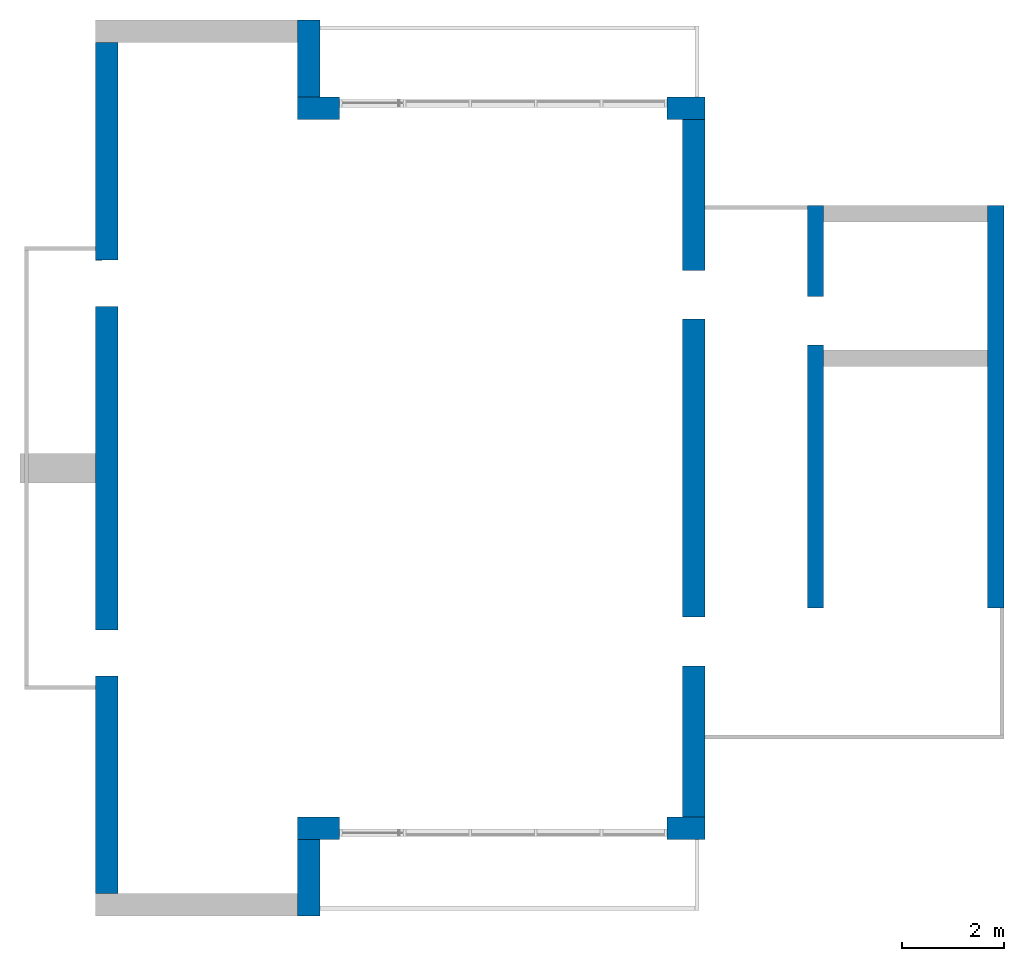
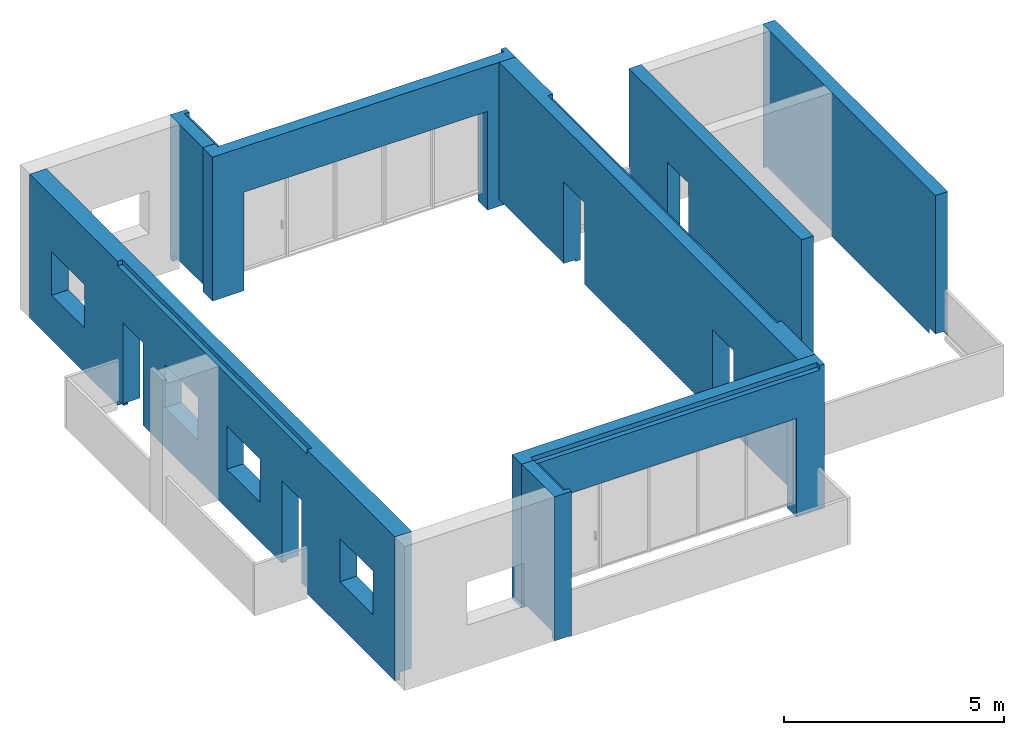
# One storey, part 3 of 4: 8 walls.
"""IFC2X3 building model written with IfcOpenShell, lengths in millimetres."""

from ifc_helpers import new_model, entity, si_unit, converted_unit, derived_unit, direction, frame, origin, place, context, subcontext, project, spatial, faceted_brep, material, material_list, layer, layer_set, type_object, element, save


model = new_model("IFC2X3")

# Units and contexts
model_context = context("Model", 3, precision=0.01, world=origin(), true_north=direction((6.12303176911189e-17, 1.0)))
body_context = subcontext(model_context, "Body", "Model", "MODEL_VIEW")
ifc_project = project(units=[si_unit("LENGTHUNIT", "METRE", prefix="MILLI"), si_unit("AREAUNIT", "SQUARE_METRE"), si_unit("VOLUMEUNIT", "CUBIC_METRE"), converted_unit("PLANEANGLEUNIT", "DEGREE", entity("IfcRatioMeasure", 0.0174532925199433), si_unit("PLANEANGLEUNIT", "RADIAN"), dimensions=[0, 0, 0, 0, 0, 0, 0]), si_unit("MASSUNIT", "GRAM", prefix="KILO"), derived_unit("MASSDENSITYUNIT", [(si_unit("MASSUNIT", "GRAM", prefix="KILO"), 1), (si_unit("LENGTHUNIT", "METRE"), -3)]), si_unit("TIMEUNIT", "SECOND"), si_unit("FREQUENCYUNIT", "HERTZ"), si_unit("THERMODYNAMICTEMPERATUREUNIT", "DEGREE_CELSIUS"), derived_unit("THERMALTRANSMITTANCEUNIT", [(si_unit("MASSUNIT", "GRAM", prefix="KILO"), 1), (si_unit("THERMODYNAMICTEMPERATUREUNIT", "KELVIN"), -1), (si_unit("TIMEUNIT", "SECOND"), -3)]), derived_unit("VOLUMETRICFLOWRATEUNIT", [(si_unit("LENGTHUNIT", "METRE"), 3), (si_unit("TIMEUNIT", "SECOND"), -1)]), si_unit("ELECTRICCURRENTUNIT", "AMPERE"), si_unit("ELECTRICVOLTAGEUNIT", "VOLT"), si_unit("POWERUNIT", "WATT"), si_unit("FORCEUNIT", "NEWTON", prefix="KILO"), si_unit("ILLUMINANCEUNIT", "LUX"), si_unit("LUMINOUSFLUXUNIT", "LUMEN"), si_unit("LUMINOUSINTENSITYUNIT", "CANDELA"), derived_unit("USERDEFINED", [(si_unit("MASSUNIT", "GRAM", prefix="KILO"), -1), (si_unit("LENGTHUNIT", "METRE"), -2), (si_unit("TIMEUNIT", "SECOND"), 3), (si_unit("LUMINOUSFLUXUNIT", "LUMEN"), 1)]), derived_unit("LINEARVELOCITYUNIT", [(si_unit("LENGTHUNIT", "METRE"), 1), (si_unit("TIMEUNIT", "SECOND"), -1)]), si_unit("PRESSUREUNIT", "PASCAL"), derived_unit("USERDEFINED", [(si_unit("LENGTHUNIT", "METRE"), -2), (si_unit("MASSUNIT", "GRAM", prefix="KILO"), 1), (si_unit("TIMEUNIT", "SECOND"), -2)])], contexts=[model_context])

# Site, building, storey
site_placement = place(None, origin())
site = spatial("IfcSite", under=ifc_project, at=site_placement, CompositionType="ELEMENT")
building_placement = place(site_placement, origin())
building = spatial("IfcBuilding", under=site, at=building_placement, CompositionType="ELEMENT")
storey_placement = place(building_placement, frame((0.0, 0.0, 4000.0)))
storey = spatial("IfcBuildingStorey", under=building, at=storey_placement, Name="01 Level", CompositionType="ELEMENT", Elevation=4000.0)

# Walls
ifc_material_1 = material(Name="03")
ifc_material_2 = material()
ifc_material_3 = material()
ifc_material_list_1 = material_list([ifc_material_1, ifc_material_2, ifc_material_3, ifc_material_1])
ifc_layer_1 = layer(ifc_material_1, 10.0)
ifc_layer_2 = layer(ifc_material_2, 120.0)
ifc_layer_3 = layer(ifc_material_3, 300.0)
ifc_layer_4 = layer(ifc_material_1, 10.0)
ifc_layer_set_1 = layer_set([ifc_layer_1, ifc_layer_2, ifc_layer_3, ifc_layer_4], Name="Basic Wall:00_fal+12 cm")
wall_type_1 = type_object("IfcWallType", Name="Basic Wall:00_fal+12 cm", PredefinedType="STANDARD", material=ifc_layer_set_1)
wall_1_placement = place(storey_placement, frame((28723.4900708518, -62021.23958514, -340.0), z_axis=(0.0, 0.0, 1.0), x_axis=(0.0, -1.0, 0.0)))
element("IfcWall", 1, at=wall_1_placement, inside=storey, type_object=wall_type_1, material=ifc_material_list_1, Name="Basic Wall:00_fal+12 cm", ObjectType="Basic Wall:00_fal+12 cm", context=body_context, shape_type="Brep", body=[
    faceted_brep([(13620.0, -220.0, 4000.0), (9620.0, -220.0, 4000.0), (9470.0, -220.0, 4000.0), (6970.0, -220.0, 4000.0), (6650.0, -220.0, 4000.0), (4150.0, -220.0, 4000.0), (4000.0, -220.0, 4000.0), (0.0, -220.0, 4000.0), (0.0, -220.0, 200.0), (2950.0, -220.0, 200.0), (2950.0, -220.0, 340.0), (2950.0, -220.0, 2465.0), (3900.0, -220.0, 2465.0), (3900.0, -220.0, 340.0), (3900.0, -220.0, 200.0), (4000.0, -220.0, 200.0), (4150.0, -220.0, 200.0), (6650.0, -220.0, 200.0), (6970.0, -220.0, 200.0), (9470.0, -220.0, 200.0), (9620.0, -220.0, 200.0), (9720.0, -220.0, 200.0), (9720.0, -220.0, 340.0), (9720.0, -220.0, 2465.0), (10670.0, -220.0, 2465.0), (10670.0, -220.0, 340.0), (10670.0, -220.0, 200.0), (13620.0, -220.0, 200.0), (10670.0, 220.0, 2465.0), (9720.0, 220.0, 2465.0), (9720.0, 220.0, 340.0), (9720.0, 220.0, 150.0), (3900.0, 220.0, 150.0), (3900.0, 220.0, 340.0), (3900.0, 220.0, 2465.0), (2950.0, 220.0, 2465.0), (2950.0, 220.0, 340.0), (2950.0, 220.0, 150.0), (1764.58460545632, 220.0, 150.0), (1694.58460545634, 220.0, 150.0), (1694.58460545634, 220.0, 0.0), (0.0, 220.0, 0.0), (0.0, 220.0, 4000.0), (1694.58460545634, 220.0, 4000.0), (1699.58460545631, 220.0, 4000.0), (1699.58460545631, 220.0, 3875.0), (12094.5846054563, 220.0, 3875.0), (12094.5846054563, 220.0, 4000.0), (13620.0, 220.0, 4000.0), (13620.0, 220.0, 0.0), (12040.0, 220.0, 0.0), (12039.5846054563, 220.0, 0.0), (12039.5846054563, 220.0, 150.0), (12024.5846054563, 220.0, 150.0), (10670.0, 220.0, 150.0), (10670.0, 220.0, 340.0), (1694.58460545634, 90.0, 0.0), (0.0, 90.0, 0.0), (13620.0, 90.0, 4000.0), (12094.5846054563, 90.0, 4000.0), (1699.58460545631, 90.0, 4000.0), (0.0, 90.0, 4000.0), (9720.0, -120.0, 200.0), (9720.0, 90.0, 200.0), (9720.0, 90.0, 150.0), (10670.0, 90.0, 150.0), (10670.0, 90.0, 200.0), (10670.0, -120.0, 200.0), (3900.0, 90.0, 150.0), (3900.0, 90.0, 200.0), (3900.0, -120.0, 200.0), (2950.0, -120.0, 200.0), (2950.0, 90.0, 200.0), (2950.0, 90.0, 150.0), (12039.5846054563, 90.0, 150.0), (12039.5846054563, 90.0, 0.0), (1694.58460545634, 90.0, 150.0), (13620.0, 90.0, 200.0), (0.0, 90.0, 200.0), (13620.0, 90.0, 0.0), (1699.58460545631, 90.0, 3875.0), (12094.5846054563, 90.0, 3875.0)], [[[0, 1, 2, 3, 4, 5, 6, 7, 8, 9, 10, 11, 12, 13, 14, 15, 16, 17, 18, 19, 20, 21, 22, 23, 24, 25, 26, 27]], [[28, 29, 30, 31, 32, 33, 34, 35, 36, 37, 38, 39, 40, 41, 42, 43, 44, 45, 46, 47, 48, 49, 50, 51, 52, 53, 54, 55]], [[41, 40, 56, 57]], [[7, 6, 5, 4, 3, 2, 1, 0, 58, 48, 47, 59, 60, 44, 43, 42, 61]], [[29, 23, 22, 21, 62, 63, 64, 31, 30]], [[24, 23, 29, 28]], [[24, 28, 55, 54, 65, 66, 67, 26, 25]], [[12, 34, 33, 32, 68, 69, 70, 14, 13]], [[12, 11, 35, 34]], [[35, 11, 10, 9, 71, 72, 73, 37, 36]], [[52, 74, 65, 54, 53]], [[74, 52, 51, 75]], [[39, 76, 56, 40]], [[77, 27, 26, 67, 66]], [[57, 56, 76, 73, 72, 78]], [[48, 58, 0, 27, 77, 79, 49]], [[7, 61, 42, 41, 57, 78, 8]], [[80, 81, 46, 45]], [[81, 80, 60, 59]], [[60, 80, 45, 44]], [[81, 59, 47, 46]], [[75, 79, 77, 66, 65, 74]], [[68, 64, 63, 69]], [[8, 78, 72, 71, 9]], [[21, 20, 19, 18, 17, 16, 15, 14, 70, 69, 63, 62]], [[64, 68, 32, 31]], [[76, 39, 38, 37, 73]], [[51, 50, 49, 79, 75]]]),
])
wall_2_placement = place(storey_placement, frame((21203.4900708518, -76081.2395851399, -340.0), z_axis=(0.0, 0.0, 1.0), x_axis=(0.0, -1.0, 0.0)))
element("IfcWall", 2, at=wall_2_placement, inside=storey, type_object=wall_type_1, Name="Basic Wall:00_fal+12 cm", ObjectType="Basic Wall:00_fal+12 cm", context=body_context, shape_type="Brep", body=[
    faceted_brep([(1500.0, -220.0, 4000.0), (1370.0, -220.0, 4000.0), (1060.0, -220.0, 4000.0), (0.0, -220.0, 4000.0), (0.0, -220.0, 200.0), (1370.0, -220.0, 200.0), (1370.0, -220.0, 0.0), (1500.0, -220.0, 0.0), (1500.0, 220.0, 4000.0), (1500.0, 220.0, 0.0), (1370.0, 220.0, 0.0), (1370.0, 220.0, 150.0), (1305.0, 220.0, 150.0), (0.0, 220.0, 150.0), (0.0, 220.0, 3875.0), (1370.0, 220.0, 3875.0), (1370.0, 220.0, 4000.0), (1370.0, 90.0, 0.0), (1370.0, 90.0, 4000.0), (0.0, 90.0, 4000.0), (1370.0, 90.0, 3875.0), (0.0, 90.0, 3875.0), (0.0, 90.0, 150.0), (0.0, 90.0, 200.0), (1370.0, 90.0, 200.0), (1370.0, 90.0, 150.0)], [[[0, 1, 2, 3, 4, 5, 6, 7]], [[8, 9, 10, 11, 12, 13, 14, 15, 16]], [[9, 7, 6, 17, 10]], [[3, 2, 1, 0, 8, 16, 18, 19]], [[7, 9, 8, 0]], [[20, 15, 14, 21]], [[20, 18, 16, 15]], [[18, 20, 21, 19]], [[3, 19, 21, 14, 13, 22, 23, 4]], [[23, 24, 5, 4]], [[24, 23, 22, 25]], [[5, 24, 25, 11, 10, 17, 6]], [[11, 25, 22, 13, 12]]]),
])
wall_3_placement = place(storey_placement, frame((17263.4900708518, -77141.2395851399, -340.0), z_axis=(0.0, 0.0, 1.0), x_axis=(0.0, 1.0, 0.0)))
element("IfcWall", 3, at=wall_3_placement, inside=storey, type_object=wall_type_1, Name="Basic Wall:00_fal+12 cm", ObjectType="Basic Wall:00_fal+12 cm", context=body_context, shape_type="Brep", body=[
    faceted_brep([(16620.0, -220.0, 4000.0), (12620.0, -220.0, 4000.0), (12470.0, -220.0, 4000.0), (8470.0, -220.0, 4000.0), (8150.0, -220.0, 4000.0), (4150.0, -220.0, 4000.0), (4000.0, -220.0, 4000.0), (0.0, -220.0, 4000.0), (0.0, -220.0, 200.0), (4000.0, -220.0, 200.0), (4150.0, -220.0, 200.0), (4250.0, -220.0, 200.0), (4250.0, -220.0, 2440.0), (5150.0, -220.0, 2440.0), (5150.0, -220.0, 200.0), (8150.0, -220.0, 200.0), (8470.0, -220.0, 200.0), (11470.0, -220.0, 200.0), (11470.0, -220.0, 2440.0), (12370.0, -220.0, 2440.0), (12370.0, -220.0, 200.0), (12470.0, -220.0, 200.0), (12620.0, -220.0, 200.0), (16620.0, -220.0, 200.0), (7650.0, -220.0, 2440.0), (7650.0, -220.0, 1240.0), (6150.0, -220.0, 1240.0), (6150.0, -220.0, 2440.0), (2500.0, -220.0, 2440.0), (2500.0, -220.0, 1240.0), (1000.0, -220.0, 1240.0), (1000.0, -220.0, 2440.0), (8970.0, -220.0, 1240.0), (8970.0, -220.0, 2440.0), (10470.0, -220.0, 2440.0), (10470.0, -220.0, 1240.0), (14120.0, -220.0, 1240.0), (14120.0, -220.0, 2440.0), (15620.0, -220.0, 2440.0), (15620.0, -220.0, 1240.0), (0.0, 220.0, 0.0), (0.0, 220.0, 4000.0), (4000.0, 220.0, 4000.0), (4000.0, 220.0, 3875.0), (8020.0, 220.0, 3875.0), (8590.0, 220.0, 3875.0), (12620.0, 220.0, 3875.0), (12620.0, 220.0, 4000.0), (16620.0, 220.0, 4000.0), (16620.0, 220.0, 0.0), (12620.0, 220.0, 0.0), (12620.0, 220.0, 150.0), (12555.0, 220.0, 150.0), (12360.0, 220.0, 150.0), (12360.0, 220.0, 200.0), (12370.0, 220.0, 200.0), (12370.0, 220.0, 340.0), (12370.0, 220.0, 2440.0), (11470.0, 220.0, 2440.0), (11470.0, 220.0, 340.0), (11460.0, 220.0, 340.0), (11460.0, 220.0, 150.0), (8590.0, 220.0, 150.0), (8020.0, 220.0, 150.0), (5150.0, 220.0, 150.0), (5150.0, 220.0, 340.0), (5150.0, 220.0, 2440.0), (4250.0, 220.0, 2440.0), (4250.0, 220.0, 340.0), (4250.0, 220.0, 150.0), (4065.0, 220.0, 150.0), (4000.0, 220.0, 150.0), (4000.0, 220.0, 0.0), (7650.0, 220.0, 1240.0), (7650.0, 220.0, 2440.0), (6150.0, 220.0, 2440.0), (6150.0, 220.0, 1240.0), (2500.0, 220.0, 1240.0), (2500.0, 220.0, 2440.0), (1000.0, 220.0, 2440.0), (1000.0, 220.0, 1240.0), (8970.0, 220.0, 2440.0), (8970.0, 220.0, 1240.0), (10470.0, 220.0, 1240.0), (10470.0, 220.0, 2440.0), (14120.0, 220.0, 2440.0), (14120.0, 220.0, 1240.0), (15620.0, 220.0, 1240.0), (15620.0, 220.0, 2440.0), (4000.0, 90.0, 0.0), (0.0, 90.0, 0.0), (16620.0, 90.0, 4000.0), (12620.0, 90.0, 4000.0), (4000.0, 90.0, 4000.0), (0.0, 90.0, 4000.0), (0.0, 90.0, 200.0), (4250.0, -120.0, 200.0), (4250.0, 90.0, 200.0), (4250.0, 90.0, 150.0), (5150.0, 90.0, 150.0), (5150.0, 90.0, 200.0), (5150.0, -120.0, 200.0), (16620.0, 90.0, 200.0), (16620.0, 90.0, 0.0), (12370.0, 90.0, 200.0), (12360.0, 90.0, 200.0), (11470.0, -120.0, 200.0), (11470.0, -120.0, 340.0), (4000.0, 90.0, 150.0), (12620.0, 90.0, 150.0), (12620.0, 90.0, 0.0), (4000.0, 90.0, 3875.0), (12620.0, 90.0, 3875.0), (11460.0, -120.0, 340.0), (11460.0, -120.0, 200.0), (11460.0, 90.0, 200.0), (11460.0, 90.0, 150.0), (12360.0, 90.0, 150.0)], [[[0, 1, 2, 3, 4, 5, 6, 7, 8, 9, 10, 11, 12, 13, 14, 15, 16, 17, 18, 19, 20, 21, 22, 23], [24, 25, 26, 27], [28, 29, 30, 31], [32, 33, 34, 35], [36, 37, 38, 39]], [[40, 41, 42, 43, 44, 45, 46, 47, 48, 49, 50, 51, 52, 53, 54, 55, 56, 57, 58, 59, 60, 61, 62, 63, 64, 65, 66, 67, 68, 69, 70, 71, 72], [73, 74, 75, 76], [77, 78, 79, 80], [81, 82, 83, 84], [85, 86, 87, 88]], [[40, 72, 89, 90]], [[7, 6, 5, 4, 3, 2, 1, 0, 91, 48, 47, 92, 93, 42, 41, 94]], [[7, 94, 41, 40, 90, 95, 8]], [[12, 11, 96, 97, 98, 69, 68, 67]], [[13, 12, 67, 66]], [[14, 13, 66, 65, 64, 99, 100, 101]], [[49, 48, 91, 0, 23, 102, 103]], [[104, 55, 54, 105]], [[20, 19, 57, 56, 55, 104]], [[58, 57, 19, 18]], [[18, 17, 106, 107, 59, 58]], [[74, 73, 25, 24]], [[75, 74, 24, 27]], [[76, 75, 27, 26]], [[73, 76, 26, 25]], [[78, 77, 29, 28]], [[79, 78, 28, 31]], [[80, 79, 31, 30]], [[77, 80, 30, 29]], [[33, 32, 82, 81]], [[34, 33, 81, 84]], [[35, 34, 84, 83]], [[32, 35, 83, 82]], [[37, 36, 86, 85]], [[38, 37, 85, 88]], [[39, 38, 88, 87]], [[36, 39, 87, 86]], [[108, 71, 70, 69, 98]], [[109, 51, 50, 110]], [[71, 108, 89, 72]], [[23, 22, 21, 20, 104, 102]], [[90, 89, 108, 98, 97, 95]], [[111, 112, 46, 45, 44, 43]], [[112, 92, 47, 46]], [[112, 111, 93, 92]], [[93, 111, 43, 42]], [[113, 60, 59, 107]], [[60, 113, 114, 115, 116, 61]], [[113, 107, 106, 114]], [[54, 53, 117, 105]], [[110, 103, 102, 104, 105, 117, 109]], [[100, 99, 116, 115]], [[14, 101, 100, 115, 114, 106, 17, 16, 15]], [[8, 95, 97, 96, 11, 10, 9]], [[51, 109, 117, 53, 52]], [[64, 63, 62, 61, 116, 99]], [[50, 49, 103, 110]]]),
])
wall_4_placement = place(storey_placement, frame((21203.4900708518, -61581.2395851399, -340.0), z_axis=(0.0, 0.0, 1.0), x_axis=(0.0, 1.0, 0.0)))
element("IfcWall", 4, at=wall_4_placement, inside=storey, type_object=wall_type_1, Name="Basic Wall:00_fal+12 cm", ObjectType="Basic Wall:00_fal+12 cm", context=body_context, shape_type="Brep", body=[
    faceted_brep([(1500.0, -220.0, 0.0), (1500.0, -220.0, 4000.0), (1370.0, -220.0, 4000.0), (1370.0, -220.0, 3875.0), (0.0, -220.0, 3875.0), (0.0, -220.0, 150.0), (1305.0, -220.0, 150.0), (1370.0, -220.0, 150.0), (1370.0, -220.0, 0.0), (0.0, 220.0, 4000.0), (1060.0, 220.0, 4000.0), (1370.0, 220.0, 4000.0), (1500.0, 220.0, 4000.0), (1500.0, 220.0, 0.0), (1370.0, 220.0, 0.0), (1370.0, 220.0, 200.0), (0.0, 220.0, 200.0), (1370.0, -90.0, 0.0), (0.0, -90.0, 4000.0), (1370.0, -90.0, 4000.0), (0.0, -90.0, 150.0), (0.0, -90.0, 3875.0), (0.0, -90.0, 200.0), (1370.0, -90.0, 150.0), (1370.0, -90.0, 200.0), (1370.0, -90.0, 3875.0)], [[[0, 1, 2, 3, 4, 5, 6, 7, 8]], [[9, 10, 11, 12, 13, 14, 15, 16]], [[13, 0, 8, 17, 14]], [[12, 11, 10, 9, 18, 19, 2, 1]], [[0, 13, 12, 1]], [[20, 5, 4, 21, 18, 9, 16, 22]], [[23, 7, 6, 5, 20]], [[7, 23, 24, 15, 14, 17, 8]], [[15, 24, 22, 16]], [[24, 23, 20, 22]], [[3, 25, 21, 4]], [[25, 19, 18, 21]], [[19, 25, 3, 2]]]),
])
wall_5_placement = place(storey_placement, frame((28943.4900708518, -75861.2395851399, -340.0), z_axis=(0.0, 0.0, 1.0), x_axis=(-1.0, 0.0, 0.0)))
element("IfcWall", 5, at=wall_5_placement, inside=storey, type_object=wall_type_1, Name="Basic Wall:00_fal+12 cm", ObjectType="Basic Wall:00_fal+12 cm", context=body_context, shape_type="Brep", body=[
    faceted_brep([(0.0, -220.0, 0.0), (130.0, -220.0, 0.0), (740.0, -220.0, 0.0), (740.0, -220.0, 200.0), (740.0, -220.0, 340.0), (740.0, -220.0, 2740.0), (7140.0, -220.0, 2740.0), (7140.0, -220.0, 340.0), (7140.0, -220.0, 200.0), (7140.0, -220.0, 0.0), (7960.0, -220.0, 0.0), (7960.0, -220.0, 200.0), (7960.0, -220.0, 4000.0), (7640.0, -220.0, 4000.0), (440.0, -220.0, 4000.0), (0.0, -220.0, 4000.0), (740.0, 220.0, 0.0), (0.0, 220.0, 0.0), (0.0, 220.0, 4000.0), (130.0, 220.0, 4000.0), (130.0, 220.0, 3875.0), (7520.0, 220.0, 3875.0), (7650.0, 220.0, 3875.0), (7650.0, 220.0, 4000.0), (7960.0, 220.0, 4000.0), (7960.0, 220.0, 0.0), (7520.0, 220.0, 0.0), (7140.0, 220.0, 0.0), (7140.0, 220.0, 150.0), (7140.0, 220.0, 340.0), (7140.0, 220.0, 2740.0), (740.0, 220.0, 2740.0), (740.0, 220.0, 340.0), (740.0, 220.0, 150.0), (7650.0, 90.0, 4000.0), (130.0, 90.0, 4000.0), (130.0, 90.0, 3875.0), (7650.0, 90.0, 3875.0)], [[[0, 1, 2, 3, 4, 5, 6, 7, 8, 9, 10, 11, 12, 13, 14, 15]], [[16, 17, 18, 19, 20, 21, 22, 23, 24, 25, 26, 27, 28, 29, 30, 31, 32, 33]], [[5, 31, 30, 6]], [[2, 1, 0, 17, 16]], [[15, 14, 13, 12, 24, 23, 34, 35, 19, 18]], [[31, 5, 4, 3, 2, 16, 33, 32]], [[6, 30, 29, 28, 27, 9, 8, 7]], [[10, 9, 27, 26, 25]], [[17, 0, 15, 18]], [[10, 25, 24, 12, 11]], [[36, 37, 22, 21, 20]], [[37, 36, 35, 34]], [[35, 36, 20, 19]], [[37, 34, 23, 22]]]),
])
wall_6_placement = place(storey_placement, frame((28943.4900708518, -61801.23958514, -340.0), z_axis=(0.0, 0.0, 1.0), x_axis=(-1.0, 0.0, 0.0)))
element("IfcWall", 6, at=wall_6_placement, inside=storey, type_object=wall_type_1, Name="Basic Wall:00_fal+12 cm", ObjectType="Basic Wall:00_fal+12 cm", context=body_context, shape_type="Brep", body=[
    faceted_brep([(0.0, -220.0, 0.0), (740.0, -220.0, 0.0), (740.0, -220.0, 150.0), (740.0, -220.0, 340.0), (740.0, -220.0, 2740.0), (7140.0, -220.0, 2740.0), (7140.0, -220.0, 340.0), (7140.0, -220.0, 150.0), (7140.0, -220.0, 0.0), (7520.0, -220.0, 0.0), (7650.0, -220.0, 0.0), (7960.0, -220.0, 0.0), (7960.0, -220.0, 4000.0), (7650.0, -220.0, 4000.0), (7650.0, -220.0, 3875.0), (130.0, -220.0, 3875.0), (130.0, -220.0, 4000.0), (0.0, -220.0, 4000.0), (740.0, 220.0, 0.0), (440.0, 220.0, 0.0), (130.0, 220.0, 0.0), (0.0, 220.0, 0.0), (0.0, 220.0, 4000.0), (440.0, 220.0, 4000.0), (740.0, 220.0, 4000.0), (7140.0, 220.0, 4000.0), (7640.0, 220.0, 4000.0), (7960.0, 220.0, 4000.0), (7960.0, 220.0, 200.0), (7960.0, 220.0, 0.0), (7140.0, 220.0, 0.0), (7140.0, 220.0, 200.0), (7140.0, 220.0, 340.0), (7140.0, 220.0, 2740.0), (740.0, 220.0, 2740.0), (740.0, 220.0, 340.0), (740.0, 220.0, 200.0), (130.0, -90.0, 4000.0), (7650.0, -90.0, 4000.0), (7650.0, -90.0, 3875.0), (130.0, -90.0, 3875.0)], [[[0, 1, 2, 3, 4, 5, 6, 7, 8, 9, 10, 11, 12, 13, 14, 15, 16, 17]], [[18, 19, 20, 21, 22, 23, 24, 25, 26, 27, 28, 29, 30, 31, 32, 33, 34, 35, 36]], [[4, 34, 33, 5]], [[1, 0, 21, 20, 19, 18]], [[27, 26, 25, 24, 23, 22, 17, 16, 37, 38, 13, 12]], [[34, 4, 3, 2, 1, 18, 36, 35]], [[5, 33, 32, 31, 30, 8, 7, 6]], [[11, 10, 9, 8, 30, 29]], [[21, 0, 17, 22]], [[11, 29, 28, 27, 12]], [[39, 40, 15, 14]], [[38, 39, 14, 13]], [[40, 37, 16, 15]], [[40, 39, 38, 37]]]),
])
ifc_material_list_2 = material_list([ifc_material_1, ifc_material_3, ifc_material_1])
ifc_layer_5 = layer(ifc_material_1, 10.0)
ifc_layer_6 = layer(ifc_material_3, 300.0)
ifc_layer_7 = layer(ifc_material_1, 10.0)
ifc_layer_set_2 = layer_set([ifc_layer_5, ifc_layer_6, ifc_layer_7], Name="Basic Wall:00_fal 300 mm")
wall_type_2 = type_object("IfcWallType", Name="Basic Wall:00_fal 300 mm", PredefinedType="STANDARD", material=ifc_layer_set_2)
wall_7_placement = place(storey_placement, frame((31103.4900708518, -63705.8241905964, -340.0), z_axis=(0.0, 0.0, 1.0), x_axis=(0.0, -1.0, 0.0)))
element("IfcWall", 7, at=wall_7_placement, inside=storey, type_object=wall_type_2, material=ifc_material_list_2, Name="Basic Wall:00_fal 300 mm", ObjectType="Basic Wall:00_fal 300 mm", context=body_context, shape_type="Brep", body=[
    faceted_brep([(7855.0, -160.0, 4000.0), (15.0, -160.0, 4000.0), (10.0, -160.0, 4000.0), (0.0, -160.0, 4000.0), (0.0, -160.0, 3875.0), (0.0, -160.0, 1290.0), (0.0, -160.0, 0.0), (10.0, -160.0, 0.0), (10.0, -160.0, 150.0), (80.0, -160.0, 150.0), (1770.0, -160.0, 150.0), (1770.0, -160.0, 340.0), (1770.0, -160.0, 2465.0), (2720.0, -160.0, 2465.0), (2720.0, -160.0, 340.0), (2720.0, -160.0, 150.0), (7855.0, -160.0, 150.0), (7855.0, -160.0, 340.0), (0.0, 160.0, 4000.0), (10.0, 160.0, 4000.0), (320.0, 160.0, 4000.0), (2820.0, 160.0, 4000.0), (3130.0, 160.0, 4000.0), (3140.0, 160.0, 4000.0), (7855.0, 160.0, 4000.0), (7855.0, 160.0, 340.0), (7855.0, 160.0, 150.0), (7855.0, 160.0, 0.0), (3140.0, 160.0, 0.0), (3130.0, 160.0, 0.0), (3130.0, 160.0, 150.0), (2820.0, 160.0, 150.0), (2720.0, 160.0, 150.0), (2720.0, 160.0, 340.0), (2720.0, 160.0, 2465.0), (1770.0, 160.0, 2465.0), (1770.0, 160.0, 340.0), (1770.0, 160.0, 150.0), (320.0, 160.0, 150.0), (10.0, 160.0, 150.0), (10.0, 160.0, 0.0), (0.0, 160.0, 0.0), (7855.0, 150.0, 150.0), (7855.0, 150.0, 0.0), (2720.0, 60.0, 150.0), (1770.0, 60.0, 150.0), (3130.0, 150.0, 150.0), (3130.0, 150.0, 0.0)], [[[0, 1, 2, 3, 4, 5, 6, 7, 8, 9, 10, 11, 12, 13, 14, 15, 16, 17]], [[18, 19, 20, 21, 22, 23, 24, 25, 26, 27, 28, 29, 30, 31, 32, 33, 34, 35, 36, 37, 38, 39, 40, 41]], [[7, 6, 41, 40]], [[24, 0, 17, 16, 42, 43, 27, 26, 25]], [[3, 2, 1, 0, 24, 23, 22, 21, 20, 19, 18]], [[13, 34, 33, 32, 44, 15, 14]], [[34, 13, 12, 35]], [[35, 12, 11, 10, 45, 37, 36]], [[46, 42, 16, 15, 44, 32, 31, 30]], [[39, 8, 7, 40]], [[47, 46, 30, 29]], [[42, 46, 47, 43]], [[41, 6, 5, 4, 3, 18]], [[8, 39, 38, 37, 45, 10, 9]], [[29, 28, 27, 43, 47]]]),
])
wall_8_placement = place(storey_placement, frame((34623.4900708518, -63705.8241905964, -340.0), z_axis=(0.0, 0.0, 1.0), x_axis=(0.0, -1.0, 0.0)))
element("IfcWall", 8, at=wall_8_placement, inside=storey, type_object=wall_type_2, Name="Basic Wall:00_fal 300 mm", ObjectType="Basic Wall:00_fal 300 mm", context=body_context, shape_type="Brep", body=[
    faceted_brep([(7855.0, -160.0, 4000.0), (7575.0, -160.0, 4000.0), (3140.0, -160.0, 4000.0), (3130.0, -160.0, 4000.0), (2820.0, -160.0, 4000.0), (320.0, -160.0, 4000.0), (10.0, -160.0, 4000.0), (0.0, -160.0, 4000.0), (0.0, -160.0, 0.0), (10.0, -160.0, 0.0), (10.0, -160.0, 150.0), (320.0, -160.0, 150.0), (2820.0, -160.0, 150.0), (3130.0, -160.0, 150.0), (3130.0, -160.0, 0.0), (3140.0, -160.0, 0.0), (7575.0, -160.0, 0.0), (7575.0, -160.0, 150.0), (7855.0, -160.0, 150.0), (7855.0, 160.0, 0.0), (0.0, 160.0, 0.0), (0.0, 160.0, 4000.0), (7855.0, 160.0, 4000.0), (7855.0, 160.0, 1290.0), (3130.0, -150.0, 0.0), (7575.0, -150.0, 0.0), (7855.0, 150.0, 4000.0), (7575.0, -150.0, 150.0), (3130.0, -150.0, 150.0), (10.0, 150.0, 150.0), (7855.0, 150.0, 150.0), (7855.0, 80.0, 150.0), (10.0, 150.0, 0.0), (7855.0, 150.0, 0.0)], [[[0, 1, 2, 3, 4, 5, 6, 7, 8, 9, 10, 11, 12, 13, 14, 15, 16, 17, 18]], [[19, 20, 21, 22, 23]], [[16, 15, 14, 24, 25]], [[7, 6, 5, 4, 3, 2, 1, 0, 26, 22, 21]], [[8, 7, 21, 20]], [[27, 28, 13, 12, 11, 10, 29, 30, 31, 18, 17]], [[29, 32, 33, 30]], [[32, 29, 10, 9]], [[28, 27, 25, 24]], [[28, 24, 14, 13]], [[25, 27, 17, 16]], [[22, 26, 0, 18, 31, 30, 33, 19, 23]], [[20, 19, 33, 32, 9, 8]]]),
])

save(model, "model.ifc")
